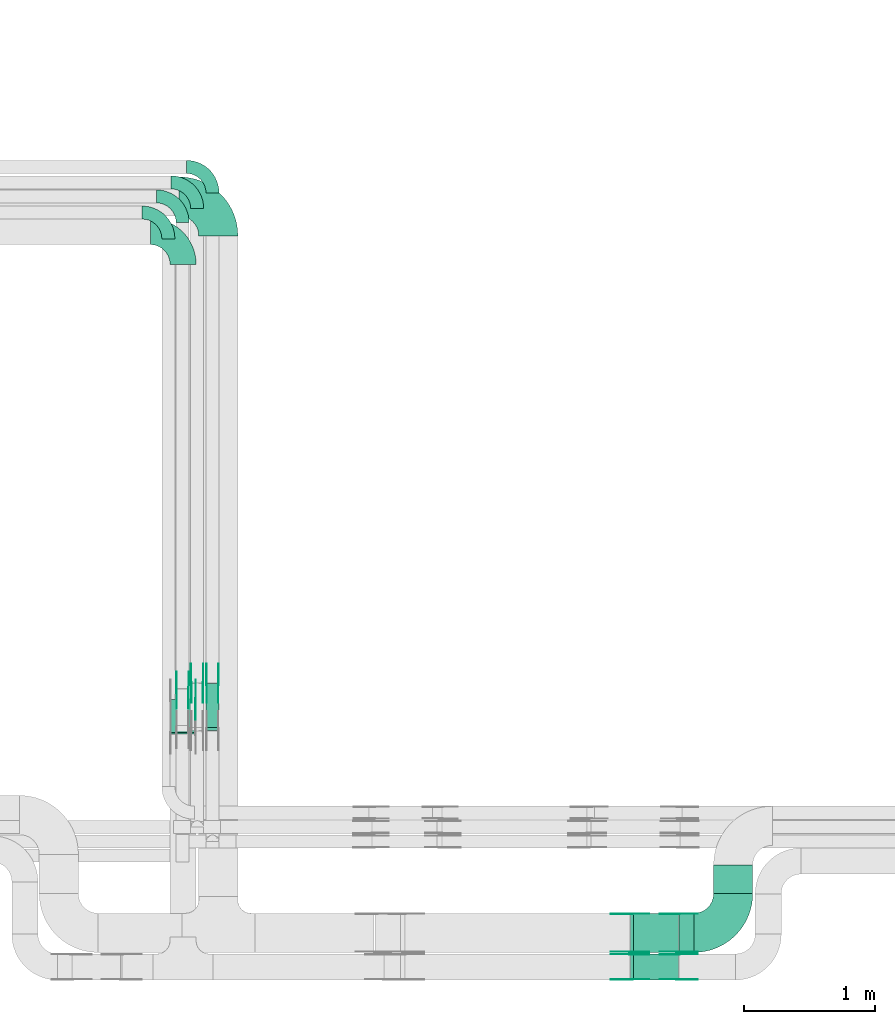
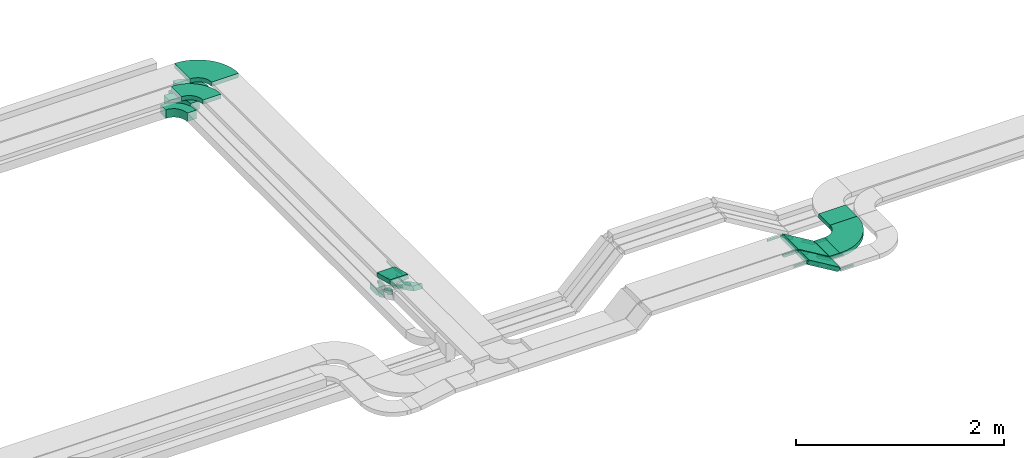
# One storey, part 16 of 19: 37 flow fittings, 6 flow segments.
"""IFC2X3 building model written with IfcOpenShell, lengths in millimetres."""

from ifc_helpers import new_model, entity, si_unit, converted_unit, derived_unit, direction, frame, frame_2d, origin, origin_2d_with_axis, place, context, subcontext, project, spatial, polyline, circle_curve, parameter, trimmed, segment, composite_curve, rectangle, outline, extrude, source, transform, mapped, material, type_object, type_shapes, element, save


model = new_model("IFC2X3")

# Units and contexts
model_context = context("Model", 3, precision=0.01, world=origin(), true_north=direction((6.12303176911189e-17, 1.0)))
body_context = subcontext(model_context, "Body", "Model", "MODEL_VIEW")
ifc_project = project(units=[si_unit("LENGTHUNIT", "METRE", prefix="MILLI"), si_unit("AREAUNIT", "SQUARE_METRE"), si_unit("VOLUMEUNIT", "CUBIC_METRE"), converted_unit("PLANEANGLEUNIT", "DEGREE", entity("IfcRatioMeasure", 0.0174532925199433), si_unit("PLANEANGLEUNIT", "RADIAN"), dimensions=[0, 0, 0, 0, 0, 0, 0]), si_unit("MASSUNIT", "GRAM", prefix="KILO"), derived_unit("MASSDENSITYUNIT", [(si_unit("MASSUNIT", "GRAM", prefix="KILO"), 1), (si_unit("LENGTHUNIT", "METRE"), -3)]), derived_unit("MOMENTOFINERTIAUNIT", [(si_unit("LENGTHUNIT", "METRE"), 4)]), si_unit("TIMEUNIT", "SECOND"), si_unit("FREQUENCYUNIT", "HERTZ"), si_unit("THERMODYNAMICTEMPERATUREUNIT", "DEGREE_CELSIUS"), derived_unit("THERMALTRANSMITTANCEUNIT", [(si_unit("MASSUNIT", "GRAM", prefix="KILO"), 1), (si_unit("THERMODYNAMICTEMPERATUREUNIT", "KELVIN"), -1), (si_unit("TIMEUNIT", "SECOND"), -3)]), derived_unit("VOLUMETRICFLOWRATEUNIT", [(si_unit("LENGTHUNIT", "METRE"), 3), (si_unit("TIMEUNIT", "SECOND"), -1)]), derived_unit("MASSFLOWRATEUNIT", [(si_unit("MASSUNIT", "GRAM", prefix="KILO"), 1), (si_unit("TIMEUNIT", "SECOND"), -1)]), derived_unit("ROTATIONALFREQUENCYUNIT", [(si_unit("TIMEUNIT", "SECOND"), -1)]), si_unit("ELECTRICCURRENTUNIT", "AMPERE"), si_unit("ELECTRICVOLTAGEUNIT", "VOLT"), si_unit("POWERUNIT", "WATT"), si_unit("FORCEUNIT", "NEWTON", prefix="KILO"), si_unit("ILLUMINANCEUNIT", "LUX"), si_unit("LUMINOUSFLUXUNIT", "LUMEN"), si_unit("LUMINOUSINTENSITYUNIT", "CANDELA"), derived_unit("USERDEFINED", [(si_unit("MASSUNIT", "GRAM", prefix="KILO"), -1), (si_unit("LENGTHUNIT", "METRE"), -2), (si_unit("TIMEUNIT", "SECOND"), 3), (si_unit("LUMINOUSFLUXUNIT", "LUMEN"), 1)]), derived_unit("LINEARVELOCITYUNIT", [(si_unit("LENGTHUNIT", "METRE"), 1), (si_unit("TIMEUNIT", "SECOND"), -1)]), si_unit("PRESSUREUNIT", "PASCAL"), derived_unit("USERDEFINED", [(si_unit("LENGTHUNIT", "METRE"), -2), (si_unit("MASSUNIT", "GRAM", prefix="KILO"), 1), (si_unit("TIMEUNIT", "SECOND"), -2)]), derived_unit("LINEARFORCEUNIT", [(si_unit("MASSUNIT", "GRAM", prefix="KILO"), 1), (si_unit("LENGTHUNIT", "METRE"), 1), (si_unit("TIMEUNIT", "SECOND"), -2), (si_unit("LENGTHUNIT", "METRE"), -1)]), derived_unit("PLANARFORCEUNIT", [(si_unit("MASSUNIT", "GRAM", prefix="KILO"), 1), (si_unit("LENGTHUNIT", "METRE"), 1), (si_unit("TIMEUNIT", "SECOND"), -2), (si_unit("LENGTHUNIT", "METRE"), -2)])], contexts=[model_context])

# Site, building, storey
site_placement = place(None, frame((0.0, -0.00077364408347762, 0.0)))
site = spatial("IfcSite", under=ifc_project, at=site_placement, CompositionType="ELEMENT")
building_placement = place(site_placement, origin())
building = spatial("IfcBuilding", under=site, at=building_placement, CompositionType="ELEMENT")
storey_placement = place(building_placement, frame((0.0, 0.0, 12000.0)))
storey = spatial("IfcBuildingStorey", under=building, at=storey_placement, CompositionType="ELEMENT", Elevation=12000.0)

# Flow segments
cable_carrier_segment_type = type_object("IfcCableCarrierSegmentType", PredefinedType="CABLETRAYSEGMENT")
flow_segment_1_placement = place(storey_placement, frame((60368.3480842056, 10524.8667454405, 2506.33963819352)))
element("IfcFlowSegment", 1, at=flow_segment_1_placement, inside=storey, type_object=cable_carrier_segment_type, context=body_context, shape_type="SweptSolid", body=[
    extrude(rectangle(XDim=50.0000000000023, YDim=380.559499598904, at=frame_2d((0.0, 0.0), x_axis=(0.0, 1.0))), frame((0.0, 180.890260985729, 108.660361806483), z_axis=(1.0, 0.0, 0.0), x_axis=(0.0, -0.891006524188357, 0.453990499739568)), (0.0, 0.0, 1.0), 99.9999999999945),
])
flow_segment_2_placement = place(storey_placement, frame((60092.5531425995, 10497.9314525157, 2802.09882442517)))
element("IfcFlowSegment", 2, at=flow_segment_2_placement, inside=storey, type_object=cable_carrier_segment_type, context=body_context, shape_type="SweptSolid", body=[
    extrude(rectangle(XDim=49.999999999998, YDim=260.823386500712, at=frame_2d((7.67386154620908e-13, 1.32516220219259e-12), x_axis=(0.0, 1.0))), frame((0.0, 132.438498688169, 57.9011755744941), z_axis=(1.0, 0.0, 0.0), x_axis=(0.0, -0.965925826289048, 0.258819045102596)), (0.0, 0.0, 1.0), 200.000000000006),
])
flow_segment_3_placement = place(storey_placement, frame((63618.5036950823, 8824.98776832001, 2808.17213422594)))
element("IfcFlowSegment", 3, at=flow_segment_3_placement, inside=storey, type_object=cable_carrier_segment_type, context=body_context, shape_type="SweptSolid", body=[
    extrude(rectangle(XDim=49.9999999999925, YDim=299.999999999999, at=frame_2d((1.08002495835535e-12, 0.0), x_axis=(0.0, 1.0))), frame((12.834101714214, 150.0, 227.201458472839), z_axis=(0.858170923011643, 0.0, -0.513364068568637), x_axis=(0.0, 1.0, 0.0)), (0.0, 0.0, 1.0), 400.782208952029),
])
flow_segment_4_placement = place(storey_placement, frame((63618.5112214411, 8613.81713290522, 2808.172134226)))
element("IfcFlowSegment", 4, at=flow_segment_4_placement, inside=storey, type_object=cable_carrier_segment_type, context=body_context, shape_type="SweptSolid", body=[
    extrude(rectangle(XDim=49.9999999999925, YDim=200.0, at=frame_2d((1.08713038571295e-12, 0.0), x_axis=(0.0, 1.0))), frame((12.834101714214, 100.0, 227.196956150436), z_axis=(0.858170923011643, 0.0, -0.513364068568637), x_axis=(0.0, 1.0, 0.0)), (0.0, 0.0, 1.0), 400.773438719208),
])
flow_segment_5_placement = place(storey_placement, frame((63992.023163891, 8824.98776832, 2800.0)))
element("IfcFlowSegment", 5, at=flow_segment_5_placement, inside=storey, type_object=cable_carrier_segment_type, context=body_context, shape_type="SweptSolid", body=[
    extrude(rectangle(XDim=113.412526248783, YDim=300.000000000001, at=origin_2d_with_axis()), frame((56.7062631243914, 150.0, 0.0)), (0.0, 0.0, 1.0), 49.9999999999995),
])
flow_segment_6_placement = place(storey_placement, frame((64256.4356901398, 9275.98776831999, 2800.0)))
element("IfcFlowSegment", 6, at=flow_segment_6_placement, inside=storey, type_object=cable_carrier_segment_type, context=body_context, shape_type="SweptSolid", body=[
    extrude(rectangle(XDim=218.000000000032, YDim=300.000000000001, at=frame_2d((5.40012479177676e-13, 8.65441052155802e-12), x_axis=(1.0, 0.0))), frame((150.0, 109.0, 0.0), z_axis=(0.0, 0.0, 1.0), x_axis=(0.0, 1.0, 0.0)), (0.0, 0.0, 1.0), 50.0000000000016),
])

# Flow fittings
ifc_material_1 = material(Name="G")
cable_carrier_fitting_type_1 = type_object("IfcCableCarrierFittingType", PredefinedType="NOTDEFINED", material=ifc_material_1)
shared_shape_1 = source(origin(), body_context, "Body", "SweptSolid", [
    extrude(outline(composite_curve([segment(trimmed(circle_curve(frame_2d((-44.5901162790698, 0.0), x_axis=(1.0, 0.0)), 12.5), [parameter(90.0000000000007)], [parameter(270.0)], True, "PARAMETER"), True, "CONTINUOUS"), segment(polyline([(-44.5901162790697, -12.5), (-33.0901162790698, -12.5)]), True, "CONTINUOUS"), segment(polyline([(-33.0901162790698, -12.5), (-31.2296511627907, -14.5)]), True, "CONTINUOUS"), segment(polyline([(-31.2296511627907, -14.5), (108.90988372093, -14.5)]), True, "CONTINUOUS"), segment(polyline([(108.90988372093, -14.5), (108.90988372093, 14.5)]), True, "CONTINUOUS"), segment(polyline([(108.90988372093, 14.5), (-31.2296511627907, 14.5)]), True, "CONTINUOUS"), segment(polyline([(-31.2296511627907, 14.5), (-33.0901162790698, 12.5)]), True, "CONTINUOUS"), segment(polyline([(-33.0901162790698, 12.5), (-44.5901162790699, 12.5)]), True, "CONTINUOUS")], self_intersect=False)), frame((44.5901162790698, 0.0, 0.0), z_axis=(0.0, 0.0, -1.0), x_axis=(1.0, 0.0, 0.0)), (0.0, 0.0, -1.0), 2.0),
])
type_shapes(cable_carrier_fitting_type_1, [shared_shape_1])
for number, where, z_axis, x_axis in (
    (7, (63623.6040100611, 9120.44776833017, 3040.0), (0.0, 1.0, 0.0), (0.858170923011649, 0.0, -0.513364068568627)),
    (8, (63623.61153642, 8618.35713289507, 3039.99549767764), (0.0, -1.0, 0.0), (-1.0, 0.0, 0.0)),
    (9, (60463.8080842157, 10882.3919519217, 2525.0), (1.0, 0.0, 0.0), (0.0, 1.0, 0.0)),
    (10, (60346.2378409759, 10882.3919519216, 2525.0), (1.0, 0.0, 0.0), (0.0, 1.0, 0.0)),
    (11, (60288.0131426097, 10760.9917294686, 2825.0), (1.0, 0.0, 0.0), (0.0, 1.0, 0.0)),
    (12, (63983.0112217149, 8829.52776830985, 2825.0), (0.0, -1.0, 0.0), (1.0, 0.0, 0.0)),
    (13, (63983.0112217149, 8618.35713289506, 2825.0), (0.0, -1.0, 0.0), (1.0, 0.0, 0.0)),
):
    element("IfcFlowFitting", number, at=place(storey_placement, frame(where, z_axis=z_axis, x_axis=x_axis)), inside=storey, type_object=cable_carrier_fitting_type_1, material=ifc_material_1, context=body_context, shape_type="MappedRepresentation", body=[
        mapped(shared_shape_1, transform((0.0, 0.0, 0.0), scale=1.0)),
    ])
cable_carrier_fitting_type_2 = type_object("IfcCableCarrierFittingType", PredefinedType="NOTDEFINED", material=ifc_material_1)
shared_shape_2 = source(origin(), body_context, "Body", "SweptSolid", [
    extrude(outline(composite_curve([segment(trimmed(circle_curve(frame_2d((-44.5901162790697, 0.0), x_axis=(1.0, 0.0)), 12.5), [parameter(90.0000000000007)], [parameter(270.0)], True, "PARAMETER"), True, "CONTINUOUS"), segment(polyline([(-44.5901162790697, -12.5), (-33.0901162790697, -12.5)]), True, "CONTINUOUS"), segment(polyline([(-33.0901162790697, -12.5), (-31.2296511627907, -14.5)]), True, "CONTINUOUS"), segment(polyline([(-31.2296511627907, -14.5), (108.90988372093, -14.5)]), True, "CONTINUOUS"), segment(polyline([(108.90988372093, -14.5), (108.90988372093, 14.5)]), True, "CONTINUOUS"), segment(polyline([(108.90988372093, 14.5), (-31.2296511627907, 14.5)]), True, "CONTINUOUS"), segment(polyline([(-31.2296511627907, 14.5), (-33.0901162790698, 12.5)]), True, "CONTINUOUS"), segment(polyline([(-33.0901162790698, 12.5), (-44.5901162790699, 12.5)]), True, "CONTINUOUS")], self_intersect=False)), frame((44.5901162790697, 0.0, 0.0)), (0.0, 0.0, 1.0), 2.0),
])
type_shapes(cable_carrier_fitting_type_2, [shared_shape_2])
for number, where, z_axis, x_axis in (
    (14, (63623.6040100611, 8829.52776830985, 3040.0), (0.0, -1.0, 0.0), (0.858170923011649, 0.0, -0.513364068568627)),
    (15, (63623.61153642, 8809.27713291538, 3039.99549767765), (0.0, 1.0, 0.0), (-1.0, 0.0, 0.0)),
    (16, (60372.8880841954, 10882.3919519217, 2525.0), (-1.0, 0.0, 0.0), (0.0, 1.0, 0.0)),
    (17, (60255.3178409556, 10882.3919519216, 2525.0), (-1.0, 0.0, 0.0), (0.0, 1.0, 0.0)),
    (18, (63983.0112217149, 9120.44776833017, 2825.0), (0.0, 1.0, 0.0), (1.0, 0.0, 0.0)),
    (19, (63983.0112217149, 8809.27713291538, 2825.0), (0.0, 1.0, 0.0), (1.0, 0.0, 0.0)),
):
    element("IfcFlowFitting", number, at=place(storey_placement, frame(where, z_axis=z_axis, x_axis=x_axis)), inside=storey, type_object=cable_carrier_fitting_type_2, material=ifc_material_1, context=body_context, shape_type="MappedRepresentation", body=[
        mapped(shared_shape_2, transform((0.0, 0.0, 0.0), scale=1.0)),
    ])
cable_carrier_fitting_type_3 = type_object("IfcCableCarrierFittingType", PredefinedType="NOTDEFINED", material=ifc_material_1)
shared_shape_3 = source(origin(), body_context, "Body", "SweptSolid", [
    extrude(outline(composite_curve([segment(trimmed(circle_curve(frame_2d((-44.5901162790698, 0.0), x_axis=(1.0, 0.0)), 12.5), [parameter(90.0000000000007)], [parameter(270.0)], True, "PARAMETER"), True, "CONTINUOUS"), segment(polyline([(-44.5901162790697, -12.5), (-33.0901162790698, -12.5)]), True, "CONTINUOUS"), segment(polyline([(-33.0901162790698, -12.5), (-31.2296511627907, -14.5)]), True, "CONTINUOUS"), segment(polyline([(-31.2296511627907, -14.5), (108.90988372093, -14.5)]), True, "CONTINUOUS"), segment(polyline([(108.90988372093, -14.5), (108.90988372093, 14.5)]), True, "CONTINUOUS"), segment(polyline([(108.90988372093, 14.5), (-31.2296511627907, 14.5)]), True, "CONTINUOUS"), segment(polyline([(-31.2296511627907, 14.5), (-33.0901162790698, 12.5)]), True, "CONTINUOUS"), segment(polyline([(-33.0901162790698, 12.5), (-44.5901162790699, 12.5)]), True, "CONTINUOUS")], self_intersect=False)), frame((44.5901162790698, 0.0, 0.0), z_axis=(0.0, 0.0, -1.0), x_axis=(1.0, 0.0, 0.0)), (0.0, 0.0, -1.0), 2.0),
])
type_shapes(cable_carrier_fitting_type_3, [shared_shape_3])
for number, where, z_axis, x_axis in (
    (20, (63623.6040100611, 8831.52776830985, 3040.0), (0.0, -1.0, 0.0), (-1.0, 0.0, 0.0)),
    (21, (63623.61153642, 8807.27713291538, 3039.99549767765), (0.0, 1.0, 0.0), (0.858170923011644, 0.0, -0.513364068568636)),
    (22, (60374.8880841954, 10882.3919519217, 2525.0), (-1.0, 0.0, 0.0), (0.0, -0.891006524188381, 0.453990499739522)),
    (23, (60257.3178409556, 10882.3919519217, 2525.0), (-1.0, 0.0, 0.0), (0.0, -0.891006524188381, 0.453990499739522)),
    (24, (63983.0112217149, 9118.44776833017, 2825.0), (0.0, 1.0, 0.0), (-0.858170923011648, 0.0, 0.51336406856863)),
    (25, (63983.0112217149, 8807.27713291538, 2825.0), (0.0, 1.0, 0.0), (-0.858170923011649, 0.0, 0.513364068568627)),
):
    element("IfcFlowFitting", number, at=place(storey_placement, frame(where, z_axis=z_axis, x_axis=x_axis)), inside=storey, type_object=cable_carrier_fitting_type_3, material=ifc_material_1, context=body_context, shape_type="MappedRepresentation", body=[
        mapped(shared_shape_3, transform((0.0, 0.0, 0.0), scale=1.0)),
    ])
cable_carrier_fitting_type_4 = type_object("IfcCableCarrierFittingType", PredefinedType="NOTDEFINED", material=ifc_material_1)
shared_shape_4 = source(origin(), body_context, "Body", "SweptSolid", [
    extrude(outline(composite_curve([segment(trimmed(circle_curve(frame_2d((-44.5901162790697, 0.0), x_axis=(1.0, 0.0)), 12.5), [parameter(90.0000000000007)], [parameter(270.0)], True, "PARAMETER"), True, "CONTINUOUS"), segment(polyline([(-44.5901162790697, -12.5), (-33.0901162790697, -12.5)]), True, "CONTINUOUS"), segment(polyline([(-33.0901162790697, -12.5), (-31.2296511627907, -14.5)]), True, "CONTINUOUS"), segment(polyline([(-31.2296511627907, -14.5), (108.90988372093, -14.5)]), True, "CONTINUOUS"), segment(polyline([(108.90988372093, -14.5), (108.90988372093, 14.5)]), True, "CONTINUOUS"), segment(polyline([(108.90988372093, 14.5), (-31.2296511627907, 14.5)]), True, "CONTINUOUS"), segment(polyline([(-31.2296511627907, 14.5), (-33.0901162790698, 12.5)]), True, "CONTINUOUS"), segment(polyline([(-33.0901162790698, 12.5), (-44.5901162790699, 12.5)]), True, "CONTINUOUS")], self_intersect=False)), frame((44.5901162790697, 0.0, 0.0)), (0.0, 0.0, 1.0), 2.0),
])
type_shapes(cable_carrier_fitting_type_4, [shared_shape_4])
for number, where, z_axis, x_axis in (
    (26, (63623.6040100611, 9118.44776833016, 3040.0), (0.0, 1.0, 0.0), (-1.0, 0.0, 0.0)),
    (27, (63623.61153642, 8620.35713289507, 3039.99549767764), (0.0, -1.0, 0.0), (0.858170923011644, 0.0, -0.513364068568636)),
    (28, (60461.8080842157, 10882.3919519217, 2525.0), (1.0, 0.0, 0.0), (0.0, -0.891006524188381, 0.453990499739522)),
    (29, (60344.2378409759, 10882.3919519217, 2525.0), (1.0, 0.0, 0.0), (0.0, -0.891006524188381, 0.453990499739522)),
    (30, (60286.0131426097, 10760.9917294686, 2825.0), (1.0, 0.0, 0.0), (0.0, -0.965925826289068, 0.258819045102522)),
    (31, (63983.0112217149, 8831.52776830986, 2825.0), (0.0, -1.0, 0.0), (-0.858170923011648, 0.0, 0.51336406856863)),
    (32, (63983.0112217149, 8620.35713289506, 2825.0), (0.0, -1.0, 0.0), (-0.858170923011649, 0.0, 0.513364068568627)),
):
    element("IfcFlowFitting", number, at=place(storey_placement, frame(where, z_axis=z_axis, x_axis=x_axis)), inside=storey, type_object=cable_carrier_fitting_type_4, material=ifc_material_1, context=body_context, shape_type="MappedRepresentation", body=[
        mapped(shared_shape_4, transform((0.0, 0.0, 0.0), scale=1.0)),
    ])
ifc_material_2 = material()
cable_carrier_fitting_type_5 = type_object("IfcCableCarrierFittingType", Name="470_DKC_S5_Variable Angle Elbow 0-45:-", PredefinedType="NOTDEFINED", material=ifc_material_2)
shared_shape_5 = source(origin(), body_context, "Body", "SweptSolid", [
    extrude(outline(composite_curve([segment(polyline([(-150.749999999996, -300.250000000003), (-149.749999999994, -300.250000000003)]), True, "CONTINUOUS"), segment(trimmed(circle_curve(frame_2d((-149.750000000002, 149.749999999997), x_axis=(0.0, -1.0)), 450.0), [parameter(0.0)], [parameter(90.0000000000001)], True, "PARAMETER"), True, "CONTINUOUS"), segment(polyline([(300.249999999997, 149.750000000005), (300.249999999997, 150.750000000004)]), True, "CONTINUOUS"), segment(polyline([(300.249999999997, 150.750000000003), (0.249999999997449, 150.750000000002)]), True, "CONTINUOUS"), segment(polyline([(0.249999999997449, 150.750000000002), (0.249999999997438, 149.75)]), True, "CONTINUOUS"), segment(trimmed(circle_curve(frame_2d((-149.750000000002, 149.749999999997), x_axis=(0.0, -1.0)), 150.0), [parameter(0.0)], [parameter(90.0000000000001)], True, "PARAMETER"), False, "CONTINUOUS"), segment(polyline([(-149.749999999999, -0.250000000002818), (-150.750000000001, -0.250000000002835)]), True, "CONTINUOUS"), segment(polyline([(-150.750000000001, -0.250000000002835), (-150.749999999996, -300.250000000003)]), True, "CONTINUOUS")], self_intersect=False)), frame((-150.249999999991, 150.249999999992, -25.0)), (0.0, 0.0, 1.0), 49.9999999999974),
])
type_shapes(cable_carrier_fitting_type_5, [shared_shape_5])
flow_fitting_1_placement = place(storey_placement, frame((60462.5531425996, 14615.2212957879, 2825.0), z_axis=(0.0, 0.0, 1.0), x_axis=(0.0, 1.0, 0.0)))
element("IfcFlowFitting", 33, at=flow_fitting_1_placement, inside=storey, type_object=cable_carrier_fitting_type_5, material=ifc_material_2, Name="470_DKC_S5_Variable Angle Elbow 0-45:-", ObjectType="470_DKC_S5_Variable Angle Elbow 0-45:-", context=body_context, shape_type="MappedRepresentation", body=[
    mapped(shared_shape_5, transform((0.0, 0.0, 0.0), scale=1.0)),
])
flow_fitting_2_placement = place(storey_placement, frame((64406.4356901398, 8974.98776832002, 2825.0)))
element("IfcFlowFitting", 34, at=flow_fitting_2_placement, inside=storey, type_object=cable_carrier_fitting_type_5, material=ifc_material_2, Name="470_DKC_S5_Variable Angle Elbow 0-45:-", ObjectType="470_DKC_S5_Variable Angle Elbow 0-45:-", context=body_context, shape_type="MappedRepresentation", body=[
    mapped(shared_shape_5, transform((0.0, 0.0, 0.0), scale=1.0)),
])
cable_carrier_fitting_type_6 = type_object("IfcCableCarrierFittingType", Name="470_DKC_S5_Variable Angle Elbow 0-45:-", PredefinedType="NOTDEFINED", material=ifc_material_2)
shared_shape_6 = source(origin(), body_context, "Body", "SweptSolid", [
    extrude(outline(composite_curve([segment(polyline([(-125.750000000004, -225.249999999998), (-124.750000000003, -225.249999999998)]), True, "CONTINUOUS"), segment(trimmed(circle_curve(frame_2d((-124.749999999998, 124.750000000002), x_axis=(0.0, -1.0)), 350.0), [parameter(0.0)], [parameter(90.0000000000001)], True, "PARAMETER"), True, "CONTINUOUS"), segment(polyline([(225.250000000002, 124.749999999996), (225.250000000002, 125.749999999995)]), True, "CONTINUOUS"), segment(polyline([(225.250000000002, 125.749999999995), (25.2500000000021, 125.750000000001)]), True, "CONTINUOUS"), segment(polyline([(25.2500000000021, 125.750000000001), (25.2500000000021, 124.749999999999)]), True, "CONTINUOUS"), segment(trimmed(circle_curve(frame_2d((-124.749999999998, 124.750000000002), x_axis=(0.0, -1.0)), 150.0), [parameter(0.0)], [parameter(90.0000000000001)], True, "PARAMETER"), False, "CONTINUOUS"), segment(polyline([(-124.75, -25.2499999999982), (-125.750000000001, -25.2499999999981)]), True, "CONTINUOUS"), segment(polyline([(-125.750000000001, -25.2499999999981), (-125.750000000004, -225.249999999998)]), True, "CONTINUOUS")], self_intersect=False)), frame((-125.249999999991, 125.249999999992, -25.0)), (0.0, 0.0, 1.0), 50.000000000001),
])
type_shapes(cable_carrier_fitting_type_6, [shared_shape_6])
flow_fitting_3_placement = place(storey_placement, frame((60192.5531425996, 14347.352728273, 2825.0), z_axis=(0.0, 0.0, 1.0), x_axis=(0.0, 1.0, 0.0)))
element("IfcFlowFitting", 35, at=flow_fitting_3_placement, inside=storey, type_object=cable_carrier_fitting_type_6, material=ifc_material_2, Name="470_DKC_S5_Variable Angle Elbow 0-45:-", ObjectType="470_DKC_S5_Variable Angle Elbow 0-45:-", context=body_context, shape_type="MappedRepresentation", body=[
    mapped(shared_shape_6, transform((0.0, 0.0, 0.0), scale=1.0)),
])
cable_carrier_fitting_type_7 = type_object("IfcCableCarrierFittingType", PredefinedType="NOTDEFINED", material=ifc_material_1)
shared_shape_7 = source(origin(), body_context, "Body", "SweptSolid", [
    extrude(outline(composite_curve([segment(trimmed(circle_curve(frame_2d((-41.4651162790697, 0.0), x_axis=(1.0, 0.0)), 25.0), [parameter(90.0000000000007)], [parameter(270.0)], True, "PARAMETER"), True, "CONTINUOUS"), segment(polyline([(-41.4651162790697, -25.0), (-29.9651162790697, -25.0)]), True, "CONTINUOUS"), segment(polyline([(-29.9651162790697, -25.0), (-28.1046511627907, -38.5)]), True, "CONTINUOUS"), segment(polyline([(-28.1046511627907, -38.5), (99.5348837209303, -38.5)]), True, "CONTINUOUS"), segment(polyline([(99.5348837209303, -38.5), (99.5348837209303, 38.5)]), True, "CONTINUOUS"), segment(polyline([(99.5348837209303, 38.5), (-28.1046511627907, 38.5)]), True, "CONTINUOUS"), segment(polyline([(-28.1046511627907, 38.5), (-29.9651162790697, 25.0)]), True, "CONTINUOUS"), segment(polyline([(-29.9651162790697, 25.0), (-41.46511627907, 25.0)]), True, "CONTINUOUS")], self_intersect=False)), frame((41.4651162790697, 0.0, 0.0), z_axis=(0.0, 0.0, -1.0), x_axis=(1.0, 0.0, 0.0)), (0.0, 0.0, -1.0), 2.0),
])
type_shapes(cable_carrier_fitting_type_7, [shared_shape_7])
flow_fitting_4_placement = place(storey_placement, frame((60234.4254894785, 10833.3266892841, 2550.0), z_axis=(1.0, 0.0, 0.0), x_axis=(0.0, 1.0, 0.0)))
element("IfcFlowFitting", 36, at=flow_fitting_4_placement, inside=storey, type_object=cable_carrier_fitting_type_7, material=ifc_material_1, context=body_context, shape_type="MappedRepresentation", body=[
    mapped(shared_shape_7, transform((0.0, 0.0, 0.0), scale=1.0)),
])
cable_carrier_fitting_type_8 = type_object("IfcCableCarrierFittingType", PredefinedType="NOTDEFINED", material=ifc_material_1)
shared_shape_8 = source(origin(), body_context, "Body", "SweptSolid", [
    extrude(outline(composite_curve([segment(trimmed(circle_curve(frame_2d((-41.4651162790697, 0.0), x_axis=(1.0, 0.0)), 25.0), [parameter(90.0000000000007)], [parameter(270.0)], True, "PARAMETER"), True, "CONTINUOUS"), segment(polyline([(-41.4651162790697, -25.0), (-29.9651162790697, -25.0)]), True, "CONTINUOUS"), segment(polyline([(-29.9651162790697, -25.0), (-28.1046511627907, -38.5)]), True, "CONTINUOUS"), segment(polyline([(-28.1046511627907, -38.5), (99.5348837209303, -38.5)]), True, "CONTINUOUS"), segment(polyline([(99.5348837209303, -38.5), (99.5348837209303, 38.5)]), True, "CONTINUOUS"), segment(polyline([(99.5348837209303, 38.5), (-28.1046511627907, 38.5)]), True, "CONTINUOUS"), segment(polyline([(-28.1046511627907, 38.5), (-29.9651162790697, 25.0)]), True, "CONTINUOUS"), segment(polyline([(-29.9651162790697, 25.0), (-41.46511627907, 25.0)]), True, "CONTINUOUS")], self_intersect=False)), frame((41.4651162790697, 0.0, 0.0)), (0.0, 0.0, 1.0), 2.0),
])
type_shapes(cable_carrier_fitting_type_8, [shared_shape_8])
flow_fitting_5_placement = place(storey_placement, frame((60143.5054894582, 10833.3266892841, 2550.0), z_axis=(-1.0, 0.0, 0.0), x_axis=(0.0, 1.0, 0.0)))
element("IfcFlowFitting", 37, at=flow_fitting_5_placement, inside=storey, type_object=cable_carrier_fitting_type_8, material=ifc_material_1, context=body_context, shape_type="MappedRepresentation", body=[
    mapped(shared_shape_8, transform((0.0, 0.0, 0.0), scale=1.0)),
])
cable_carrier_fitting_type_9 = type_object("IfcCableCarrierFittingType", PredefinedType="NOTDEFINED", material=ifc_material_1)
shared_shape_9 = source(origin(), body_context, "Body", "SweptSolid", [
    extrude(outline(composite_curve([segment(trimmed(circle_curve(frame_2d((-41.4651162790697, 0.0), x_axis=(1.0, 0.0)), 25.0), [parameter(90.0000000000007)], [parameter(270.0)], True, "PARAMETER"), True, "CONTINUOUS"), segment(polyline([(-41.4651162790697, -25.0), (-29.9651162790697, -25.0)]), True, "CONTINUOUS"), segment(polyline([(-29.9651162790697, -25.0), (-28.1046511627907, -38.5)]), True, "CONTINUOUS"), segment(polyline([(-28.1046511627907, -38.5), (99.5348837209303, -38.5)]), True, "CONTINUOUS"), segment(polyline([(99.5348837209303, -38.5), (99.5348837209303, 38.5)]), True, "CONTINUOUS"), segment(polyline([(99.5348837209303, 38.5), (-28.1046511627907, 38.5)]), True, "CONTINUOUS"), segment(polyline([(-28.1046511627907, 38.5), (-29.9651162790697, 25.0)]), True, "CONTINUOUS"), segment(polyline([(-29.9651162790697, 25.0), (-41.46511627907, 25.0)]), True, "CONTINUOUS")], self_intersect=False)), frame((41.4651162790697, 0.0, 0.0), z_axis=(0.0, 0.0, -1.0), x_axis=(1.0, 0.0, 0.0)), (0.0, 0.0, -1.0), 2.0),
])
type_shapes(cable_carrier_fitting_type_9, [shared_shape_9])
flow_fitting_6_placement = place(storey_placement, frame((60145.5054894582, 10833.3266892841, 2550.0), z_axis=(-1.0, 0.0, 0.0), x_axis=(0.0, -0.891006524188411, 0.453990499739462)))
element("IfcFlowFitting", 38, at=flow_fitting_6_placement, inside=storey, type_object=cable_carrier_fitting_type_9, material=ifc_material_1, context=body_context, shape_type="MappedRepresentation", body=[
    mapped(shared_shape_9, transform((0.0, 0.0, 0.0), scale=1.0)),
])
cable_carrier_fitting_type_10 = type_object("IfcCableCarrierFittingType", PredefinedType="NOTDEFINED", material=ifc_material_1)
shared_shape_10 = source(origin(), body_context, "Body", "SweptSolid", [
    extrude(outline(composite_curve([segment(trimmed(circle_curve(frame_2d((-41.4651162790697, 0.0), x_axis=(1.0, 0.0)), 25.0), [parameter(90.0000000000007)], [parameter(270.0)], True, "PARAMETER"), True, "CONTINUOUS"), segment(polyline([(-41.4651162790697, -25.0), (-29.9651162790697, -25.0)]), True, "CONTINUOUS"), segment(polyline([(-29.9651162790697, -25.0), (-28.1046511627907, -38.5)]), True, "CONTINUOUS"), segment(polyline([(-28.1046511627907, -38.5), (99.5348837209303, -38.5)]), True, "CONTINUOUS"), segment(polyline([(99.5348837209303, -38.5), (99.5348837209303, 38.5)]), True, "CONTINUOUS"), segment(polyline([(99.5348837209303, 38.5), (-28.1046511627907, 38.5)]), True, "CONTINUOUS"), segment(polyline([(-28.1046511627907, 38.5), (-29.9651162790697, 25.0)]), True, "CONTINUOUS"), segment(polyline([(-29.9651162790697, 25.0), (-41.46511627907, 25.0)]), True, "CONTINUOUS")], self_intersect=False)), frame((41.4651162790697, 0.0, 0.0)), (0.0, 0.0, 1.0), 2.0),
])
type_shapes(cable_carrier_fitting_type_10, [shared_shape_10])
flow_fitting_7_placement = place(storey_placement, frame((60232.4254894785, 10833.3266892841, 2550.0), z_axis=(1.0, 0.0, 0.0), x_axis=(0.0, -0.891006524188411, 0.453990499739462)))
element("IfcFlowFitting", 39, at=flow_fitting_7_placement, inside=storey, type_object=cable_carrier_fitting_type_10, material=ifc_material_1, context=body_context, shape_type="MappedRepresentation", body=[
    mapped(shared_shape_10, transform((0.0, 0.0, 0.0), scale=1.0)),
])
cable_carrier_fitting_type_11 = type_object("IfcCableCarrierFittingType", Name="470_DKC_S5_Variable Angle Elbow 0-45:-", PredefinedType="NOTDEFINED", material=ifc_material_2)
shared_shape_11 = source(origin(), body_context, "Body", "SweptSolid", [
    extrude(outline(composite_curve([segment(polyline([(-100.749999999999, -150.250000000001), (-99.7499999999981, -150.250000000001)]), True, "CONTINUOUS"), segment(trimmed(circle_curve(frame_2d((-99.7500000000006, 99.7499999999987), x_axis=(0.0, -1.0)), 250.0), [parameter(0.0)], [parameter(90.0000000000001)], True, "PARAMETER"), True, "CONTINUOUS"), segment(polyline([(150.249999999999, 99.7500000000013), (150.249999999999, 100.750000000001)]), True, "CONTINUOUS"), segment(polyline([(150.249999999999, 100.750000000001), (50.2499999999992, 100.750000000001)]), True, "CONTINUOUS"), segment(polyline([(50.2499999999992, 100.750000000001), (50.2499999999992, 99.7500000000002)]), True, "CONTINUOUS"), segment(trimmed(circle_curve(frame_2d((-99.7500000000006, 99.7499999999987), x_axis=(0.0, -1.0)), 150.0), [parameter(0.0)], [parameter(90.0000000000001)], True, "PARAMETER"), False, "CONTINUOUS"), segment(polyline([(-99.7499999999989, -50.2500000000011), (-100.75, -50.2500000000011)]), True, "CONTINUOUS"), segment(polyline([(-100.75, -50.2500000000011), (-100.749999999999, -150.250000000001)]), True, "CONTINUOUS")], self_intersect=False)), frame((-100.249999999991, 100.249999999992, -50.0)), (0.0, 0.0, 1.0), 100.0),
])
type_shapes(cable_carrier_fitting_type_11, [shared_shape_11])
for number, where, z_axis, x_axis, name in (
    (40, (60188.9654894683, 14616.2405608766, 2550.0), (0.0, 0.0, 1.0), (0.0, 1.0, 0.0), "470_DKC_S5_Variable Angle Elbow 0-45:-"),
    (41, (60079.9977539063, 14492.4967897, 2550.0), (0.0, 0.0, 1.0), (0.0, 1.0, 0.0), "470_DKC_S5_Variable Angle Elbow 0-45:-"),
):
    element("IfcFlowFitting", number, at=place(storey_placement, frame(where, z_axis=z_axis, x_axis=x_axis)), inside=storey, type_object=cable_carrier_fitting_type_11, material=ifc_material_2, Name=name, ObjectType="470_DKC_S5_Variable Angle Elbow 0-45:-", context=body_context, shape_type="MappedRepresentation", body=[
        mapped(shared_shape_11, transform((0.0, 0.0, 0.0), scale=1.0)),
    ])
cable_carrier_fitting_type_12 = type_object("IfcCableCarrierFittingType", Name="470_DKC_S5_Variable Angle Elbow 0-45:-", PredefinedType="NOTDEFINED", material=ifc_material_2)
shared_shape_12 = source(origin(), body_context, "Body", "SweptSolid", [
    extrude(outline(composite_curve([segment(polyline([(-100.750000000001, -150.25), (-99.7499999999994, -150.25)]), True, "CONTINUOUS"), segment(trimmed(circle_curve(frame_2d((-99.7499999999997, 99.7499999999995), x_axis=(0.0, -1.0)), 250.0), [parameter(0.0)], [parameter(90.0000000000001)], True, "PARAMETER"), True, "CONTINUOUS"), segment(polyline([(150.25, 99.75), (150.25, 100.749999999999)]), True, "CONTINUOUS"), segment(polyline([(150.25, 100.749999999999), (50.25, 100.75)]), True, "CONTINUOUS"), segment(polyline([(50.25, 100.75), (50.25, 99.7499999999998)]), True, "CONTINUOUS"), segment(trimmed(circle_curve(frame_2d((-99.7499999999997, 99.7499999999995), x_axis=(0.0, -1.0)), 150.0), [parameter(0.0)], [parameter(90.0000000000001)], True, "PARAMETER"), False, "CONTINUOUS"), segment(polyline([(-99.7499999999994, -50.2500000000003), (-100.750000000001, -50.2500000000003)]), True, "CONTINUOUS"), segment(polyline([(-100.750000000001, -50.2500000000003), (-100.750000000001, -150.25)]), True, "CONTINUOUS")], self_intersect=False)), frame((-100.249999999991, 100.249999999992, -25.0)), (0.0, 0.0, 1.0), 49.9999999999997),
])
type_shapes(cable_carrier_fitting_type_12, [shared_shape_12])
for number, where, z_axis, x_axis, name in (
    (42, (60418.3480842056, 14842.4967897, 2525.0), (0.0, 0.0, 1.0), (0.0, 1.0, 0.0), "470_DKC_S5_Variable Angle Elbow 0-45:-"),
    (43, (60300.7778409658, 14723.6298749258, 2525.0), (0.0, 0.0, 1.0), (0.0, 1.0, 0.0), "470_DKC_S5_Variable Angle Elbow 0-45:-"),
):
    element("IfcFlowFitting", number, at=place(storey_placement, frame(where, z_axis=z_axis, x_axis=x_axis)), inside=storey, type_object=cable_carrier_fitting_type_12, material=ifc_material_2, Name=name, ObjectType="470_DKC_S5_Variable Angle Elbow 0-45:-", context=body_context, shape_type="MappedRepresentation", body=[
        mapped(shared_shape_12, transform((0.0, 0.0, 0.0), scale=1.0)),
    ])

save(model, "model.ifc")
